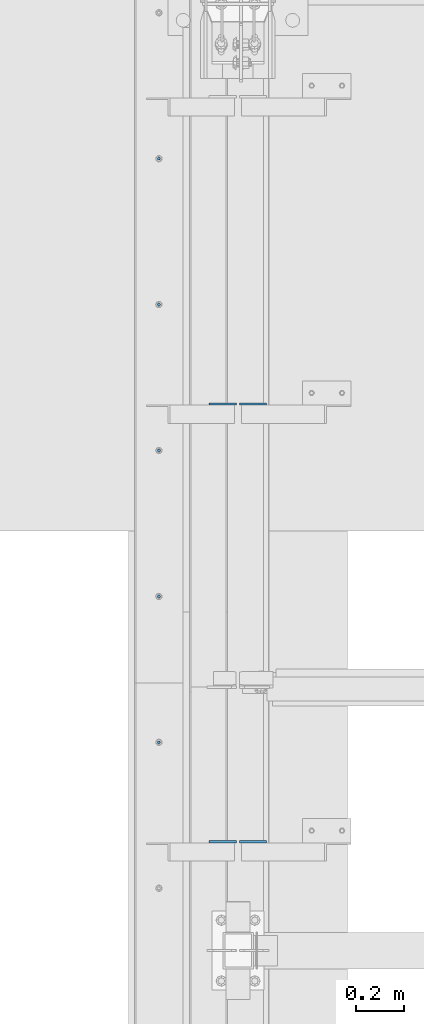
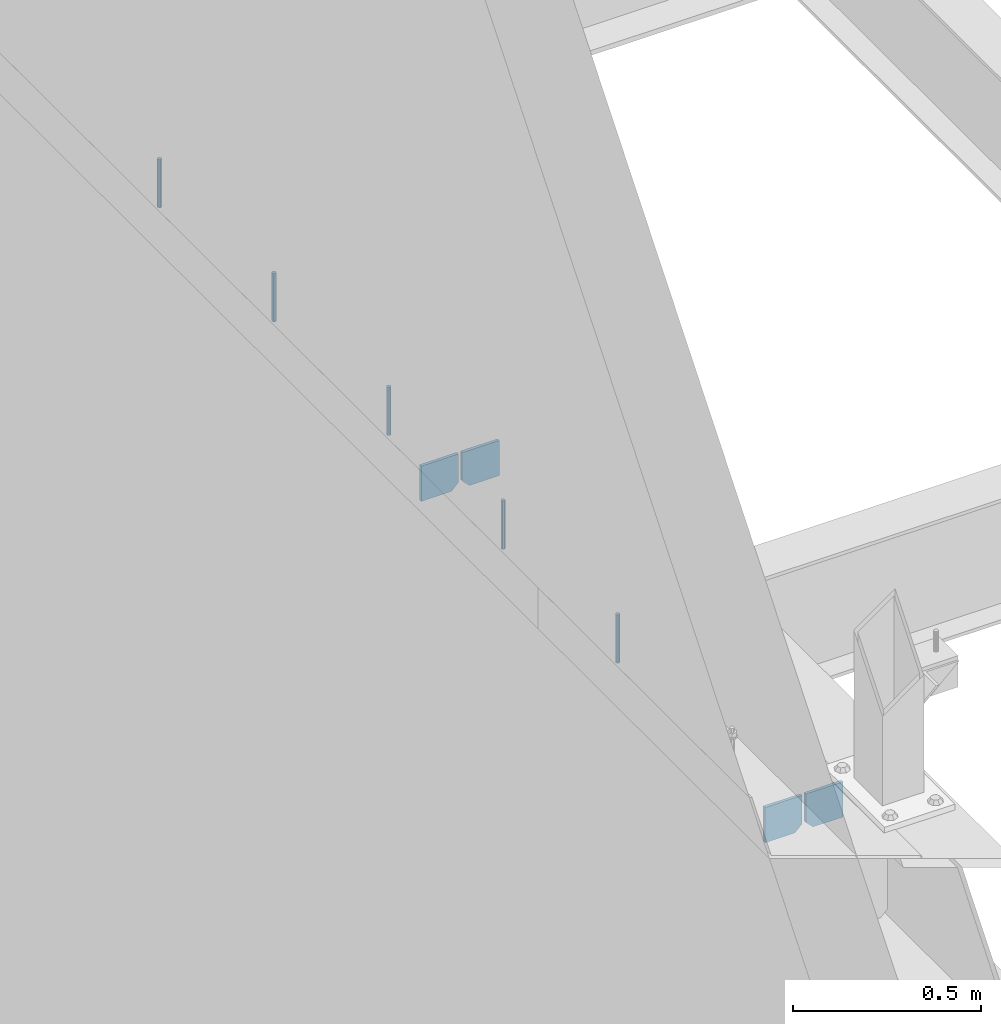
# One storey, part 386 of 1179: 9 columns, 1 element without a shape of its own.
"""IFC2X3 building model written with IfcOpenShell, lengths in millimetres."""

from ifc_helpers import new_model, si_unit, frame, origin_with_axes, place, context, subcontext, project, spatial, faceted_brep, material, type_object, element, aggregate, save


model = new_model("IFC2X3")

# Units and contexts
model_context = context("Model", 3, precision=1e-05, world=origin_with_axes())
body_context = subcontext(model_context, "Body", "Model", "MODEL_VIEW")
ifc_project = project(units=[si_unit("LENGTHUNIT", "METRE", prefix="MILLI"), si_unit("AREAUNIT", "SQUARE_METRE"), si_unit("VOLUMEUNIT", "CUBIC_METRE"), si_unit("MASSUNIT", "GRAM", prefix="KILO"), si_unit("TIMEUNIT", "SECOND"), si_unit("PLANEANGLEUNIT", "RADIAN"), si_unit("SOLIDANGLEUNIT", "STERADIAN"), si_unit("THERMODYNAMICTEMPERATUREUNIT", "DEGREE_CELSIUS"), si_unit("LUMINOUSINTENSITYUNIT", "LUMEN")], contexts=[model_context])

# Site, building, storey
site_placement = place(None, origin_with_axes())
site = spatial("IfcSite", under=ifc_project, at=site_placement, CompositionType="ELEMENT")
building_placement = place(site_placement, origin_with_axes())
building = spatial("IfcBuilding", under=site, at=building_placement, Name="Undefined", CompositionType="ELEMENT")
storey_placement = place(building_placement, origin_with_axes())
storey = spatial("IfcBuildingStorey", under=building, at=storey_placement, Name="Undefined", CompositionType="ELEMENT", Elevation=0.0)

# Assembly, columns
assembly_placement = place(storey_placement, origin_with_axes())
assembly = element("IfcElementAssembly", 1, at=assembly_placement, inside=storey, Name="BEAM", AssemblyPlace="NOTDEFINED", PredefinedType="RIGID_FRAME")
ifc_material_1 = material(Name="STEEL/A36")
column_type_1 = type_object("IfcColumnType", PredefinedType="NOTDEFINED")
column_1_placement = place(assembly_placement, frame((494.506249999995, 9649.62249128227, 3702.05), z_axis=(-1.0, 0.0, 0.0), x_axis=(0.0, 0.0, 1.0)))
column_1 = element("IfcColumn", 2, at=column_1_placement, type_object=column_type_1, material=ifc_material_1, Name="PLATE", context=body_context, shape_type="Brep", body=[
    faceted_brep([(22.2250000000004, 4.76250000000073, 57.1500000000015), (0.0, 4.76250000000073, 34.9249999999993), (0.0, -4.76250000000073, 34.9249999999993), (22.2250000000004, -4.76250000000073, 57.1500000000015), (114.300000000001, 4.76250000000073, 57.1500000000015), (114.300000000001, 4.76250000000073, -57.1500000000015), (0.0, 4.76250000000073, -57.1500000000015), (114.300000000001, -4.76250000000073, 57.1500000000015), (0.0, -4.76250000000073, -57.1500000000015), (114.300000000001, -4.76250000000073, -57.1500000000015)], [[[0, 1, 2, 3]], [[4, 5, 6, 1, 0]], [[7, 4, 0, 3]], [[8, 9, 7, 3, 2]], [[8, 6, 5, 9]], [[7, 9, 5, 4]], [[6, 8, 2, 1]]]),
])
column_2_placement = place(assembly_placement, frame((369.09375, 9649.62249128227, 3702.05), z_axis=(1.0, 0.0, 0.0), x_axis=(0.0, 0.0, 1.0)))
column_2 = element("IfcColumn", 3, at=column_2_placement, type_object=column_type_1, material=ifc_material_1, Name="PLATE", context=body_context, shape_type="Brep", body=[
    faceted_brep([(22.2250000000004, 4.76250000000073, 57.1500000000015), (0.0, 4.76250000000073, 34.9249999999993), (0.0, -4.76250000000073, 34.9249999999993), (22.2250000000004, -4.76250000000073, 57.1500000000015), (114.300000000001, 4.76250000000073, 57.1500000000015), (114.300000000001, 4.76250000000073, -57.1500000000015), (0.0, 4.76250000000073, -57.1500000000015), (114.300000000001, -4.76250000000073, 57.1500000000015), (0.0, -4.76250000000073, -57.1500000000015), (114.300000000001, -4.76250000000073, -57.1500000000015)], [[[0, 1, 2, 3]], [[4, 5, 6, 1, 0]], [[7, 4, 0, 3]], [[8, 9, 7, 3, 2]], [[8, 6, 5, 9]], [[7, 9, 5, 4]], [[6, 8, 2, 1]]]),
])
column_3_placement = place(assembly_placement, frame((494.506249999995, 7820.82249128227, 3702.05), z_axis=(-1.0, 0.0, 0.0), x_axis=(0.0, 0.0, 1.0)))
column_3 = element("IfcColumn", 4, at=column_3_placement, type_object=column_type_1, material=ifc_material_1, Name="PLATE", context=body_context, shape_type="Brep", body=[
    faceted_brep([(22.2250000000004, 4.76250000000073, 57.1500000000015), (0.0, 4.76250000000073, 34.9249999999993), (0.0, -4.76250000000073, 34.9249999999993), (22.2250000000004, -4.76250000000073, 57.1500000000015), (114.300000000001, 4.76250000000073, 57.1500000000015), (114.300000000001, 4.76250000000073, -57.1500000000015), (0.0, 4.76250000000073, -57.1500000000015), (114.300000000001, -4.76250000000073, 57.1500000000015), (0.0, -4.76250000000073, -57.1500000000015), (114.300000000001, -4.76250000000073, -57.1500000000015)], [[[0, 1, 2, 3]], [[4, 5, 6, 1, 0]], [[7, 4, 0, 3]], [[8, 9, 7, 3, 2]], [[8, 6, 5, 9]], [[7, 9, 5, 4]], [[6, 8, 2, 1]]]),
])
column_4_placement = place(assembly_placement, frame((369.09375, 7820.82249128227, 3702.05), z_axis=(1.0, 0.0, 0.0), x_axis=(0.0, 0.0, 1.0)))
column_4 = element("IfcColumn", 5, at=column_4_placement, type_object=column_type_1, material=ifc_material_1, Name="PLATE", context=body_context, shape_type="Brep", body=[
    faceted_brep([(22.2250000000004, 4.76250000000073, 57.1500000000015), (0.0, 4.76250000000073, 34.9249999999993), (0.0, -4.76250000000073, 34.9249999999993), (22.2250000000004, -4.76250000000073, 57.1500000000015), (114.300000000001, 4.76250000000073, 57.1500000000015), (114.300000000001, 4.76250000000073, -57.1500000000015), (0.0, 4.76250000000073, -57.1500000000015), (114.300000000001, -4.76250000000073, 57.1500000000015), (0.0, -4.76250000000073, -57.1500000000015), (114.300000000001, -4.76250000000073, -57.1500000000015)], [[[0, 1, 2, 3]], [[4, 5, 6, 1, 0]], [[7, 4, 0, 3]], [[8, 9, 7, 3, 2]], [[8, 6, 5, 9]], [[7, 9, 5, 4]], [[6, 8, 2, 1]]]),
])
ifc_material_2 = material(Name="STEEL/A307")
column_type_2 = type_object("IfcColumnType", PredefinedType="NOTDEFINED")
column_5_placement = place(assembly_placement, frame((101.599999999999, 10674.34975, 4108.45), z_axis=(0.0, 1.0, 0.0), x_axis=(0.0, 0.0, 1.0)))
column_5 = element("IfcColumn", 6, at=column_5_placement, type_object=column_type_2, material=ifc_material_2, Name="THREADED ROD", context=body_context, shape_type="Brep", body=[
    faceted_brep([(0.0, -6.34999999999854, 0.0), (0.0, -4.49012806053361, -4.49012806053452), (157.162499999999, -4.49012806053361, -4.49012806053361), (157.162499999999, -6.34999999999854, 0.0), (0.0, 0.0, -6.34999999999991), (157.162499999999, 0.0, -6.34999999999854), (0.0, 4.49012806053361, -4.49012806053452), (157.162499999999, 4.49012806053361, -4.49012806053361), (0.0, 6.34999999999854, 0.0), (157.162499999999, 6.34999999999854, 0.0), (0.0, 4.49012806053361, 4.49012806053452), (157.162499999999, 4.49012806053361, 4.49012806053361), (0.0, 0.0, 6.34999999999991), (157.162499999999, 0.0, 6.34999999999854), (0.0, -4.49012806053361, 4.49012806053452), (157.162499999999, -4.49012806053361, 4.49012806053361)], [[[0, 1, 2, 3]], [[1, 4, 5, 2]], [[4, 6, 7, 5]], [[6, 8, 9, 7]], [[8, 10, 11, 9]], [[10, 12, 13, 11]], [[12, 14, 15, 13]], [[14, 0, 3, 15]], [[5, 7, 9, 11, 13, 15, 3, 2]], [[14, 12, 10, 8, 6, 4, 1, 0]]]),
])
column_6_placement = place(assembly_placement, frame((101.599999999999, 10064.74975, 4108.45), z_axis=(0.0, 1.0, 0.0), x_axis=(0.0, 0.0, 1.0)))
column_6 = element("IfcColumn", 7, at=column_6_placement, type_object=column_type_2, material=ifc_material_2, Name="THREADED ROD", context=body_context, shape_type="Brep", body=[
    faceted_brep([(0.0, -6.34999999999854, 0.0), (0.0, -4.49012806053361, -4.49012806053452), (157.162499999999, -4.49012806053361, -4.49012806053361), (157.162499999999, -6.34999999999854, 0.0), (0.0, 0.0, -6.34999999999991), (157.162499999999, 0.0, -6.34999999999854), (0.0, 4.49012806053361, -4.49012806053452), (157.162499999999, 4.49012806053361, -4.49012806053361), (0.0, 6.34999999999854, 0.0), (157.162499999999, 6.34999999999854, 0.0), (0.0, 4.49012806053361, 4.49012806053452), (157.162499999999, 4.49012806053361, 4.49012806053361), (0.0, 0.0, 6.34999999999991), (157.162499999999, 0.0, 6.34999999999854), (0.0, -4.49012806053361, 4.49012806053452), (157.162499999999, -4.49012806053361, 4.49012806053361)], [[[0, 1, 2, 3]], [[1, 4, 5, 2]], [[4, 6, 7, 5]], [[6, 8, 9, 7]], [[8, 10, 11, 9]], [[10, 12, 13, 11]], [[12, 14, 15, 13]], [[14, 0, 3, 15]], [[5, 7, 9, 11, 13, 15, 3, 2]], [[14, 12, 10, 8, 6, 4, 1, 0]]]),
])
column_7_placement = place(assembly_placement, frame((101.599999999999, 9455.14975, 4108.45), z_axis=(0.0, 1.0, 0.0), x_axis=(0.0, 0.0, 1.0)))
column_7 = element("IfcColumn", 8, at=column_7_placement, type_object=column_type_2, material=ifc_material_2, Name="THREADED ROD", context=body_context, shape_type="Brep", body=[
    faceted_brep([(0.0, -6.34999999999854, 0.0), (0.0, -4.49012806053361, -4.49012806053452), (157.162499999999, -4.49012806053361, -4.49012806053361), (157.162499999999, -6.34999999999854, 0.0), (0.0, 0.0, -6.34999999999991), (157.162499999999, 0.0, -6.34999999999854), (0.0, 4.49012806053361, -4.49012806053452), (157.162499999999, 4.49012806053361, -4.49012806053361), (0.0, 6.34999999999854, 0.0), (157.162499999999, 6.34999999999854, 0.0), (0.0, 4.49012806053361, 4.49012806053452), (157.162499999999, 4.49012806053361, 4.49012806053361), (0.0, 0.0, 6.34999999999991), (157.162499999999, 0.0, 6.34999999999854), (0.0, -4.49012806053361, 4.49012806053452), (157.162499999999, -4.49012806053361, 4.49012806053361)], [[[0, 1, 2, 3]], [[1, 4, 5, 2]], [[4, 6, 7, 5]], [[6, 8, 9, 7]], [[8, 10, 11, 9]], [[10, 12, 13, 11]], [[12, 14, 15, 13]], [[14, 0, 3, 15]], [[5, 7, 9, 11, 13, 15, 3, 2]], [[14, 12, 10, 8, 6, 4, 1, 0]]]),
])
column_8_placement = place(assembly_placement, frame((101.599999999999, 8845.54975, 4108.45), z_axis=(0.0, 1.0, 0.0), x_axis=(0.0, 0.0, 1.0)))
column_8 = element("IfcColumn", 9, at=column_8_placement, type_object=column_type_2, material=ifc_material_2, Name="THREADED ROD", context=body_context, shape_type="Brep", body=[
    faceted_brep([(0.0, -6.34999999999854, 0.0), (0.0, -4.49012806053361, -4.49012806053452), (157.162499999999, -4.49012806053361, -4.49012806053361), (157.162499999999, -6.34999999999854, 0.0), (0.0, 0.0, -6.34999999999991), (157.162499999999, 0.0, -6.34999999999854), (0.0, 4.49012806053361, -4.49012806053452), (157.162499999999, 4.49012806053361, -4.49012806053361), (0.0, 6.34999999999854, 0.0), (157.162499999999, 6.34999999999854, 0.0), (0.0, 4.49012806053361, 4.49012806053452), (157.162499999999, 4.49012806053361, 4.49012806053361), (0.0, 0.0, 6.34999999999991), (157.162499999999, 0.0, 6.34999999999854), (0.0, -4.49012806053361, 4.49012806053452), (157.162499999999, -4.49012806053361, 4.49012806053361)], [[[0, 1, 2, 3]], [[1, 4, 5, 2]], [[4, 6, 7, 5]], [[6, 8, 9, 7]], [[8, 10, 11, 9]], [[10, 12, 13, 11]], [[12, 14, 15, 13]], [[14, 0, 3, 15]], [[5, 7, 9, 11, 13, 15, 3, 2]], [[14, 12, 10, 8, 6, 4, 1, 0]]]),
])
column_9_placement = place(assembly_placement, frame((101.599999999999, 8235.94975, 4108.45), z_axis=(0.0, 1.0, 0.0), x_axis=(0.0, 0.0, 1.0)))
column_9 = element("IfcColumn", 10, at=column_9_placement, type_object=column_type_2, material=ifc_material_2, Name="THREADED ROD", context=body_context, shape_type="Brep", body=[
    faceted_brep([(0.0, -6.34999999999854, 0.0), (0.0, -4.49012806053361, -4.49012806053452), (157.162499999999, -4.49012806053361, -4.49012806053361), (157.162499999999, -6.34999999999854, 0.0), (0.0, 0.0, -6.34999999999991), (157.162499999999, 0.0, -6.34999999999854), (0.0, 4.49012806053361, -4.49012806053452), (157.162499999999, 4.49012806053361, -4.49012806053361), (0.0, 6.34999999999854, 0.0), (157.162499999999, 6.34999999999854, 0.0), (0.0, 4.49012806053361, 4.49012806053452), (157.162499999999, 4.49012806053361, 4.49012806053361), (0.0, 0.0, 6.34999999999991), (157.162499999999, 0.0, 6.34999999999854), (0.0, -4.49012806053361, 4.49012806053452), (157.162499999999, -4.49012806053361, 4.49012806053361)], [[[0, 1, 2, 3]], [[1, 4, 5, 2]], [[4, 6, 7, 5]], [[6, 8, 9, 7]], [[8, 10, 11, 9]], [[10, 12, 13, 11]], [[12, 14, 15, 13]], [[14, 0, 3, 15]], [[5, 7, 9, 11, 13, 15, 3, 2]], [[14, 12, 10, 8, 6, 4, 1, 0]]]),
])
aggregate(assembly, [column_1, column_2, column_3, column_4, column_5, column_6, column_7, column_8, column_9])

save(model, "model.ifc")
